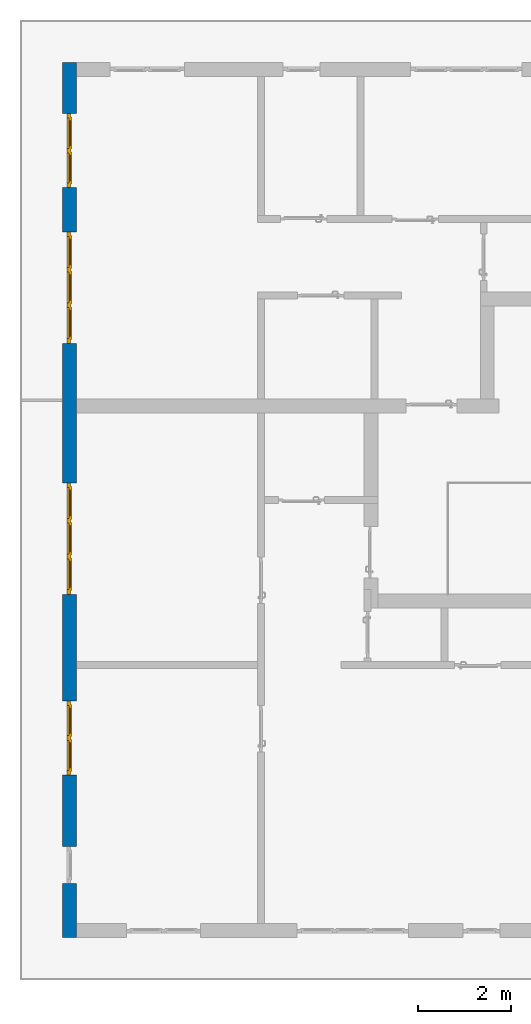
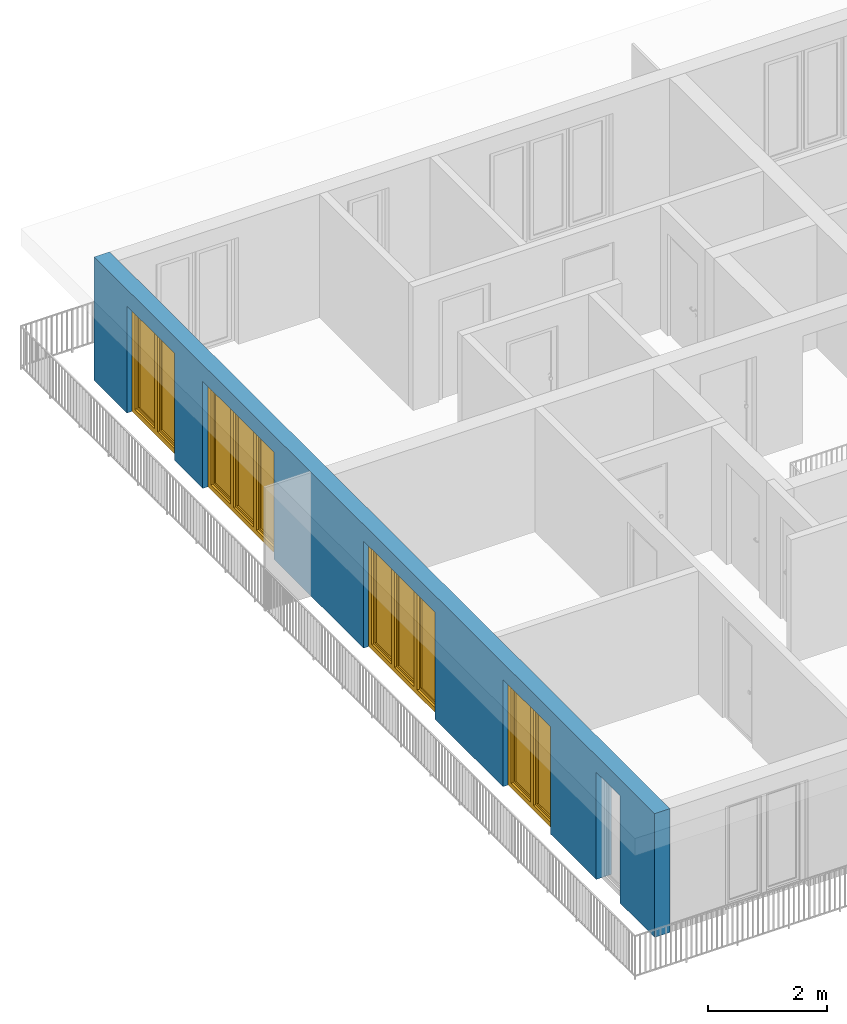
# One storey, part 11 of 54: 4 windows, 1 wall, 5 openings.
"""IFC4 building model written with IfcOpenShell, lengths in metres."""

import ifcopenshell
import ifcopenshell.guid

model = None  # the IFC model being written
_history = None  # IfcOwnerHistory: only IFC2X3 demands one
_inside = {}  # id of a spatial element -> (the spatial element, [elements in it])
_under = {}  # id of a project, library or spatial element -> (it, [spatial elements below it])
_declared = {}  # id of a project -> (the project, [libraries it declares])
_typed = {}  # id of a type object -> (the type object, [elements of that type])
_made_of = {}  # id of a material, layer set ... -> (it, [elements and type objects made of it])


def new_model(schema):
    """Start an empty IFC model of exactly this schema.

    Asked for "IFC4X3", IfcOpenShell would pick the latest addendum, in which some entities
    have other attributes; the version numbers below select the first issue.
    IFC2X3 requires an IfcOwnerHistory on every rooted entity: one is made here for all.
    """
    global model, _history
    if schema == "IFC4X3":
        model = ifcopenshell.file(schema_version=(4, 3, 0, 0))
    else:
        model = ifcopenshell.file(schema=schema)
    _inside.clear()
    _under.clear()
    _declared.clear()
    _typed.clear()
    _made_of.clear()
    _history = None
    if model.schema == "IFC2X3":
        org = make("IfcOrganization", Name="unknown")
        user = make(
            "IfcPersonAndOrganization",
            ThePerson=make("IfcPerson", FamilyName="unknown"),
            TheOrganization=org,
        )
        app = make(
            "IfcApplication",
            ApplicationDeveloper=org,
            Version="unknown",
            ApplicationFullName="unknown",
            ApplicationIdentifier="unknown",
        )
        _history = make(
            "IfcOwnerHistory",
            OwningUser=user,
            OwningApplication=app,
            ChangeAction="ADDED",
            CreationDate=0,
        )
    return model


def make(cls, **values):
    """One entity of the class cls with the attributes given. An attribute that is None is left unset."""
    return model.create_entity(
        cls, **{name: value for name, value in values.items() if value is not None}
    )


def entity(cls, *values):
    """Any entity or typed value of the class cls, its attributes in the order of the schema. None: left unset."""
    e = model.create_entity(cls)
    for i, value in enumerate(values):
        if value is not None:
            e[i] = value
    return e


def rooted(cls, **values):
    """An entity with a GlobalId (a new one), such as an element, a storey or a relation."""
    return make(cls, GlobalId=ifcopenshell.guid.new(), OwnerHistory=_history, **values)


def si_unit(unit_type, name, prefix=None):
    """IfcSIUnit, for example si_unit("LENGTHUNIT", "METRE", prefix="MILLI")."""
    return make("IfcSIUnit", UnitType=unit_type, Prefix=prefix, Name=name)


def converted_unit(unit_type, name, factor, base, dimensions=None, offset=None):
    """IfcConversionBasedUnit, such as the inch: factor (a typed value) times the base unit."""
    return make(
        "IfcConversionBasedUnit"
        if offset is None
        else "IfcConversionBasedUnitWithOffset",
        ConversionOffset=offset,
        Dimensions=None
        if dimensions is None
        else entity("IfcDimensionalExponents", *dimensions),
        UnitType=unit_type,
        Name=name,
        ConversionFactor=make(
            "IfcMeasureWithUnit", ValueComponent=factor, UnitComponent=base
        ),
    )


def derived_unit(unit_type, elements):
    """IfcDerivedUnit: a product of units, each with its exponent."""
    return make(
        "IfcDerivedUnit",
        Elements=[
            make("IfcDerivedUnitElement", Unit=unit, Exponent=power)
            for unit, power in elements
        ],
        UnitType=unit_type,
    )


def assignment(units):
    """IfcUnitAssignment: the units of a project."""
    return None if units is None else make("IfcUnitAssignment", Units=units)


def point(xyz):
    """IfcCartesianPoint."""
    return None if xyz is None else make("IfcCartesianPoint", Coordinates=xyz)


def direction(xyz):
    """IfcDirection."""
    return None if xyz is None else make("IfcDirection", DirectionRatios=xyz)


def frame(location, z_axis=None, x_axis=None):
    """IfcAxis2Placement3D, a coordinate frame: its origin and axes. An axis left out is left unset."""
    return make(
        "IfcAxis2Placement3D",
        Location=point(location),
        Axis=direction(z_axis),
        RefDirection=direction(x_axis),
    )


def origin_with_axes():
    """The frame at (0, 0, 0) with the z axis (0, 0, 1) and the x axis (1, 0, 0) written out."""
    return frame((0.0, 0.0, 0.0), z_axis=(0.0, 0.0, 1.0), x_axis=(1.0, 0.0, 0.0))


def place(relative_to, where):
    """IfcLocalPlacement: puts the frame where relative to a parent placement (None: the world)."""
    return make(
        "IfcLocalPlacement", PlacementRelTo=relative_to, RelativePlacement=where
    )


def context(
    kind, dimensions, precision=None, world=None, true_north=None, identifier=None
):
    """IfcGeometricRepresentationContext, for example the 3D "Model" context."""
    return make(
        "IfcGeometricRepresentationContext",
        ContextIdentifier=identifier,
        ContextType=kind,
        CoordinateSpaceDimension=dimensions,
        Precision=precision,
        WorldCoordinateSystem=world,
        TrueNorth=true_north,
    )


def subcontext(parent, identifier, kind, view, scale=None):
    """IfcGeometricRepresentationSubContext, for example "Body" below "Model"."""
    return make(
        "IfcGeometricRepresentationSubContext",
        ContextIdentifier=identifier,
        ContextType=kind,
        ParentContext=parent,
        TargetScale=scale,
        TargetView=view,
    )


def project(units=None, contexts=None):
    """IfcProject with its units and contexts."""
    return rooted(
        "IfcProject",
        Name="project",
        RepresentationContexts=contexts,
        UnitsInContext=assignment(units),
    )


def spatial(cls, under=None, at=None, **own):
    """A site, building, storey or space (cls), placed at a placement, below another one or the project."""
    s = rooted(cls, ObjectPlacement=at, **own)
    if under is not None:
        _under.setdefault(under.id(), (under, []))[1].append(s)
    return s


def point_list(points):
    """IfcCartesianPointList2D or 3D."""
    cls = (
        "IfcCartesianPointList2D" if len(points[0]) == 2 else "IfcCartesianPointList3D"
    )
    return make(cls, CoordList=points)


def polygons(points, faces, closed=None, point_numbers=None):
    """IfcPolygonalFaceSet: a face is its outer loop, then its inner loops; points numbered from 1."""
    made = []
    for loops in faces:
        if len(loops) == 1:
            made.append(make("IfcIndexedPolygonalFace", CoordIndex=loops[0]))
        else:
            made.append(
                make(
                    "IfcIndexedPolygonalFaceWithVoids",
                    CoordIndex=loops[0],
                    InnerCoordIndices=loops[1:],
                )
            )
    return make(
        "IfcPolygonalFaceSet",
        Coordinates=point_list(points),
        Closed=closed,
        Faces=made,
        PnIndex=point_numbers,
    )


def shape(context_of_items, identifier, shape_type, items):
    """IfcShapeRepresentation: the items that make up one representation, for example the "Body"."""
    return make(
        "IfcShapeRepresentation",
        ContextOfItems=context_of_items,
        RepresentationIdentifier=identifier,
        RepresentationType=shape_type,
        Items=items,
    )


def source(mapping_origin, context_of_items, identifier, shape_type, items):
    """IfcRepresentationMap: a shape defined once, which mapped items show again and again."""
    return make(
        "IfcRepresentationMap",
        MappingOrigin=mapping_origin,
        MappedRepresentation=shape(context_of_items, identifier, shape_type, items),
    )


def transform(
    local_origin,
    x_axis=None,
    y_axis=None,
    z_axis=None,
    scale=None,
    scale2=None,
    scale3=None,
    uniform=True,
):
    """IfcCartesianTransformationOperator3D, or its non-uniform kind. x_axis, y_axis, z_axis: its Axis1, 2, 3."""
    if uniform:
        return make(
            "IfcCartesianTransformationOperator3D",
            Axis1=direction(x_axis),
            Axis2=direction(y_axis),
            LocalOrigin=point(local_origin),
            Scale=scale,
            Axis3=direction(z_axis),
        )
    return make(
        "IfcCartesianTransformationOperator3DnonUniform",
        Axis1=direction(x_axis),
        Axis2=direction(y_axis),
        LocalOrigin=point(local_origin),
        Scale=scale,
        Axis3=direction(z_axis),
        Scale2=scale2,
        Scale3=scale3,
    )


def mapped(mapping_source, mapping_target):
    """IfcMappedItem: shows the shape of a source again, moved by a transform."""
    return make(
        "IfcMappedItem", MappingSource=mapping_source, MappingTarget=mapping_target
    )


def material(Name=None, Category=None):
    """IfcMaterial."""
    return make("IfcMaterial", Name=Name, Category=Category)


def made_of(thing, what):
    """Note that an element or type object is made of a material, layer set ...; save() writes the relation."""
    if what is not None:
        _made_of.setdefault(what.id(), (what, []))[1].append(thing)
    return thing


def type_object(cls, material=None, **own):
    """A type object (cls), such as IfcWallType, which elements share."""
    return made_of(rooted(cls, **own), material)


def element(
    cls,
    number,
    at=None,
    inside=None,
    cuts=None,
    type_object=None,
    material=None,
    context=None,
    identifier="Body",
    shape_type=None,
    held_by="IfcProductDefinitionShape",
    body=None,
    shapes=None,
    **own,
):
    """One element of the class cls, such as IfcWall. Its Tag is "e" and its number.

    at: its placement. inside: the storey or other place that contains it. cuts: it is an
    opening in that element (IfcRelVoidsElement). A single representation is given by context,
    identifier, shape_type and body (its items); several are given by shapes. held_by: the class
    of the entity that holds the representations. save() writes the other relations.
    """
    e = rooted(cls, Tag="e%d" % number, ObjectPlacement=at, **own)
    if body is not None:
        shapes = [shape(context, identifier, shape_type, body)]
    if shapes is not None:
        e.Representation = make(held_by, Representations=shapes)
    if inside is not None:
        _inside.setdefault(inside.id(), (inside, []))[1].append(e)
    if cuts is not None:
        rooted(
            "IfcRelVoidsElement", RelatingBuildingElement=cuts, RelatedOpeningElement=e
        )
    if type_object is not None:
        _typed.setdefault(type_object.id(), (type_object, []))[1].append(e)
    return made_of(e, material)


def fill(opening, filler):
    """IfcRelFillsElement: the door or window that sits in an opening."""
    return rooted(
        "IfcRelFillsElement",
        RelatingOpeningElement=opening,
        RelatedBuildingElement=filler,
    )


def aggregate(whole, parts):
    """IfcRelAggregates: a whole, such as a stair, and the parts it consists of."""
    return rooted("IfcRelAggregates", RelatingObject=whole, RelatedObjects=parts)


def save(model, path):
    """Write the relations noted so far, then the file.

    IfcRelAggregates (storeys below a building ...), IfcRelContainedInSpatialStructure (elements
    in a storey), IfcRelDefinesByType, IfcRelAssociatesMaterial and IfcRelDeclares: one each for
    every whole, place, type object, material and project.
    """
    for whole, parts in _under.values():
        aggregate(whole, parts)
    for where, things in _inside.values():
        rooted(
            "IfcRelContainedInSpatialStructure",
            RelatedElements=things,
            RelatingStructure=where,
        )
    for kind, things in _typed.values():
        rooted("IfcRelDefinesByType", RelatedObjects=things, RelatingType=kind)
    for what, things in _made_of.values():
        rooted("IfcRelAssociatesMaterial", RelatedObjects=things, RelatingMaterial=what)
    for by, libraries in _declared.values():
        rooted("IfcRelDeclares", RelatingContext=by, RelatedDefinitions=libraries)
    model.write(path)


model = new_model("IFC4")

# Units and contexts
model_context = context("Model", 3, precision=1e-05, world=origin_with_axes(), true_north=direction((0.0, 1.0)))
body_context = subcontext(model_context, "Body", "Model", "MODEL_VIEW")
ifc_project = project(units=[si_unit("LENGTHUNIT", "METRE"), si_unit("AREAUNIT", "SQUARE_METRE"), si_unit("VOLUMEUNIT", "CUBIC_METRE"), converted_unit("PLANEANGLEUNIT", "DEGREE", entity("IfcPlaneAngleMeasure", 0.0174532925199), si_unit("PLANEANGLEUNIT", "RADIAN"), dimensions=[0, 0, 0, 0, 0, 0, 0]), converted_unit("TIMEUNIT", "Year", entity("IfcTimeMeasure", 31556926.0), si_unit("TIMEUNIT", "SECOND"), dimensions=[0, 0, 1, 0, 0, 0, 0]), si_unit("MASSUNIT", "GRAM", prefix="KILO"), si_unit("THERMODYNAMICTEMPERATUREUNIT", "DEGREE_CELSIUS"), si_unit("LUMINOUSINTENSITYUNIT", "LUMEN"), si_unit("ENERGYUNIT", "JOULE", prefix="MEGA"), derived_unit("THERMALCONDUCTANCEUNIT", [(si_unit("POWERUNIT", "WATT"), 1), (si_unit("LENGTHUNIT", "METRE"), -1), (si_unit("THERMODYNAMICTEMPERATUREUNIT", "KELVIN"), -1)]), derived_unit("SPECIFICHEATCAPACITYUNIT", [(si_unit("ENERGYUNIT", "JOULE"), 1), (si_unit("MASSUNIT", "GRAM", prefix="KILO"), -1), (si_unit("THERMODYNAMICTEMPERATUREUNIT", "KELVIN"), -1)]), derived_unit("MASSDENSITYUNIT", [(si_unit("MASSUNIT", "GRAM", prefix="KILO"), 1), (si_unit("VOLUMEUNIT", "CUBIC_METRE"), -1)])], contexts=[model_context])

# Site, building, storey
site_placement = place(None, origin_with_axes())
site = spatial("IfcSite", under=ifc_project, at=site_placement, CompositionType="ELEMENT")
building_placement = place(site_placement, origin_with_axes())
building = spatial("IfcBuilding", under=site, at=building_placement, CompositionType="ELEMENT")
storey_placement = place(building_placement, frame((0.0, 0.0, 9.18), z_axis=(0.0, 0.0, 1.0), x_axis=(1.0, 0.0, 0.0)))
storey = spatial("IfcBuildingStorey", under=building, at=storey_placement, Name="3. Geschoss", CompositionType="ELEMENT", Elevation=9.18)

# Wall, openings, windows
ifc_material = material()
wall_type = type_object("IfcWallType", Name="300", PredefinedType="NOTDEFINED")
wall_placement = place(storey_placement, frame((-11.7421993804, -9.92881223104, 0.0), z_axis=(0.0, 0.0, 1.0), x_axis=(0.0, 1.0, 0.0)))
wall = element("IfcWall", 1, at=wall_placement, inside=storey, type_object=wall_type, material=ifc_material, Name="Wand-001", PredefinedType="NOTDEFINED", context=body_context, shape_type="Tessellation", body=[
    polygons([(1.16441876325, -0.3, 0.0), (1.16441876325, -0.3, 2.2), (1.96441876325, -0.3, 2.2), (1.96441876325, -0.3, 0.0), (3.5, -0.3, 0.0), (3.5, -0.3, 2.2), (5.1, -0.3, 2.2), (5.1, -0.3, 0.0), (7.3921181063, -0.3, 0.0), (7.3921181063, -0.3, 2.2), (9.7921181063, -0.3, 2.2), (9.7921181063, -0.3, 0.0), (12.8, -0.3, 0.0), (12.8, -0.3, 2.2), (15.2, -0.3, 2.2), (15.2, -0.3, 0.0), (16.15, -0.3, 0.0), (16.15, -0.3, 2.2), (17.75, -0.3, 2.2), (17.75, -0.3, 0.0), (18.85, -0.3, 0.0), (18.85, -0.3, 2.54), (0.0, -0.3, 2.54), (0.0, -0.3, 0.0), (1.16441876325, -0.1, 0.0), (1.16441876325, -0.1, 2.2), (1.96441876325, -0.1, 2.2), (1.96441876325, -0.1, 0.0), (1.96441876325, 0.0, 0.0), (3.5, 0.0, 0.0), (3.5, -0.1, 0.0), (3.5, -0.1, 2.2), (5.1, -0.1, 2.2), (5.1, -0.1, 0.0), (5.1, 0.0, 0.0), (7.3921181063, 0.0, 0.0), (7.3921181063, -0.1, 0.0), (7.3921181063, -0.1, 2.2), (9.7921181063, -0.1, 2.2), (9.7921181063, -0.1, 0.0), (9.7921181063, 0.0, 0.0), (12.8, 0.0, 0.0), (12.8, -0.1, 0.0), (12.8, -0.1, 2.2), (15.2, -0.1, 2.2), (15.2, -0.1, 0.0), (15.2, 0.0, 0.0), (16.15, 0.0, 0.0), (16.15, -0.1, 0.0), (16.15, -0.1, 2.2), (17.75, -0.1, 2.2), (17.75, -0.1, 0.0), (17.75, 0.0, 0.0), (18.85, 0.0, 0.0), (18.85, 0.0, 2.54), (0.0, 0.0, 2.54), (0.0, 0.0, 0.0), (1.16441876325, 0.0, 0.0), (1.16441876325, 0.0, 2.2), (1.96441876325, 0.0, 2.2), (17.75, 0.0, 2.2), (16.15, 0.0, 2.2), (15.2, 0.0, 2.2), (12.8, 0.0, 2.2), (9.7921181063, 0.0, 2.2), (7.3921181063, 0.0, 2.2), (5.1, 0.0, 2.2), (3.5, 0.0, 2.2)], [[[1, 2, 3, 4, 5, 6, 7, 8, 9, 10, 11, 12, 13, 14, 15, 16, 17, 18, 19, 20, 21, 22, 23, 24]], [[2, 1, 25, 26]], [[3, 2, 26, 27]], [[4, 3, 27, 28]], [[4, 28, 29, 30, 31, 5]], [[31, 32, 6, 5]], [[32, 33, 7, 6]], [[33, 34, 8, 7]], [[8, 34, 35, 36, 37, 9]], [[10, 9, 37, 38]], [[11, 10, 38, 39]], [[12, 11, 39, 40]], [[12, 40, 41, 42, 43, 13]], [[43, 44, 14, 13]], [[44, 45, 15, 14]], [[45, 46, 16, 15]], [[16, 46, 47, 48, 49, 17]], [[18, 17, 49, 50]], [[19, 18, 50, 51]], [[20, 19, 51, 52]], [[52, 53, 54, 21, 20]], [[22, 21, 54, 55]], [[22, 55, 56, 23]], [[56, 57, 24, 23]], [[25, 1, 24, 57, 58]], [[26, 25, 58, 59]], [[27, 26, 59, 60]], [[28, 27, 60, 29]], [[30, 29, 60, 59, 58, 57, 56, 55, 54, 53, 61, 62, 48, 47, 63, 64, 42, 41, 65, 66, 36, 35, 67, 68]], [[30, 68, 32, 31]], [[68, 67, 33, 32]], [[67, 35, 34, 33]], [[38, 37, 36, 66]], [[39, 38, 66, 65]], [[40, 39, 65, 41]], [[42, 64, 44, 43]], [[64, 63, 45, 44]], [[63, 47, 46, 45]], [[50, 49, 48, 62]], [[51, 50, 62, 61]], [[52, 51, 61, 53]]], closed=True),
])
opening_1_placement = place(wall_placement, frame((16.95, 0.0, 0.0), z_axis=(0.0, 0.0, 1.0), x_axis=(1.0, 0.0, 0.0)))
opening_1 = element("IfcOpeningElement", 2, at=opening_1_placement, cuts=wall, Name="Fenster-001", context=body_context, identifier="Reference", shape_type="Tessellation", body=[
    polygons([(-0.8, -0.1, 0.0), (-0.8, -0.1, 2.2), (-0.8, 0.000999999999999, 2.2), (-0.8, 0.000999999999999, 0.0), (-0.8, -0.301, 0.0), (-0.8, -0.301, 2.2), (0.8, -0.1, 2.2), (0.8, 0.000999999999999, 2.2), (0.8, -0.301, 2.2), (0.8, 0.000999999999999, 0.0), (0.8, -0.1, 0.0), (0.8, -0.301, 0.0)], [[[1, 2, 3, 4]], [[2, 1, 5, 6]], [[7, 8, 3, 2, 6, 9]], [[8, 10, 4, 3]], [[1, 4, 10, 11, 12, 5]], [[6, 5, 12, 9]], [[7, 11, 10, 8]], [[11, 7, 9, 12]]], closed=True),
])
opening_2_placement = place(wall_placement, frame((14.0, 0.0, 0.0), z_axis=(0.0, 0.0, 1.0), x_axis=(1.0, 0.0, 0.0)))
opening_2 = element("IfcOpeningElement", 3, at=opening_2_placement, cuts=wall, Name="Fenster-002", context=body_context, identifier="Reference", shape_type="Tessellation", body=[
    polygons([(-1.2, -0.1, 0.0), (-1.2, -0.1, 2.2), (-1.2, 0.000999999999999, 2.2), (-1.2, 0.000999999999999, 0.0), (-1.2, -0.301, 0.0), (-1.2, -0.301, 2.2), (1.2, -0.1, 2.2), (1.2, 0.000999999999999, 2.2), (1.2, -0.301, 2.2), (1.2, 0.000999999999999, 0.0), (1.2, -0.1, 0.0), (1.2, -0.301, 0.0)], [[[1, 2, 3, 4]], [[2, 1, 5, 6]], [[7, 8, 3, 2, 6, 9]], [[8, 10, 4, 3]], [[1, 4, 10, 11, 12, 5]], [[6, 5, 12, 9]], [[7, 11, 10, 8]], [[11, 7, 9, 12]]], closed=True),
])
opening_3_placement = place(wall_placement, frame((8.5921181063, 0.0, 0.0), z_axis=(0.0, 0.0, 1.0), x_axis=(1.0, 0.0, 0.0)))
opening_3 = element("IfcOpeningElement", 4, at=opening_3_placement, cuts=wall, Name="Fenster-002", context=body_context, identifier="Reference", shape_type="Tessellation", body=[
    polygons([(-1.2, -0.1, 0.0), (-1.2, -0.1, 2.2), (-1.2, 0.000999999999999, 2.2), (-1.2, 0.000999999999999, 0.0), (-1.2, -0.301, 0.0), (-1.2, -0.301, 2.2), (1.2, -0.1, 2.2), (1.2, 0.000999999999999, 2.2), (1.2, -0.301, 2.2), (1.2, 0.000999999999999, 0.0), (1.2, -0.1, 0.0), (1.2, -0.301, 0.0)], [[[1, 2, 3, 4]], [[2, 1, 5, 6]], [[7, 8, 3, 2, 6, 9]], [[8, 10, 4, 3]], [[1, 4, 10, 11, 12, 5]], [[6, 5, 12, 9]], [[7, 11, 10, 8]], [[11, 7, 9, 12]]], closed=True),
])
opening_4_placement = place(wall_placement, frame((4.3, 0.0, 0.0), z_axis=(0.0, 0.0, 1.0), x_axis=(1.0, 0.0, 0.0)))
opening_4 = element("IfcOpeningElement", 5, at=opening_4_placement, cuts=wall, Name="Fenster-001", context=body_context, identifier="Reference", shape_type="Tessellation", body=[
    polygons([(-0.8, -0.1, 0.0), (-0.8, -0.1, 2.2), (-0.8, 0.000999999999999, 2.2), (-0.8, 0.000999999999999, 0.0), (-0.8, -0.301, 0.0), (-0.8, -0.301, 2.2), (0.8, -0.1, 2.2), (0.8, 0.000999999999999, 2.2), (0.8, -0.301, 2.2), (0.8, 0.000999999999999, 0.0), (0.8, -0.1, 0.0), (0.8, -0.301, 0.0)], [[[1, 2, 3, 4]], [[2, 1, 5, 6]], [[7, 8, 3, 2, 6, 9]], [[8, 10, 4, 3]], [[1, 4, 10, 11, 12, 5]], [[6, 5, 12, 9]], [[7, 11, 10, 8]], [[11, 7, 9, 12]]], closed=True),
])
opening_5_placement = place(wall_placement, frame((1.56441876325, 0.0, 0.0), z_axis=(0.0, 0.0, 1.0), x_axis=(1.0, 0.0, 0.0)))
element("IfcOpeningElement", 6, at=opening_5_placement, cuts=wall, Name="Fenster-003", context=body_context, identifier="Reference", shape_type="Tessellation", body=[
    polygons([(-0.4, -0.1, 0.0), (-0.4, -0.1, 2.2), (-0.4, 0.000999999999999, 2.2), (-0.4, 0.000999999999999, 0.0), (-0.4, -0.301, 0.0), (-0.4, -0.301, 2.2), (0.4, -0.1, 2.2), (0.4, 0.000999999999999, 2.2), (0.4, -0.301, 2.2), (0.4, 0.000999999999999, 0.0), (0.4, -0.1, 0.0), (0.4, -0.301, 0.0)], [[[1, 2, 3, 4]], [[2, 1, 5, 6]], [[7, 8, 3, 2, 6, 9]], [[8, 10, 4, 3]], [[1, 4, 10, 11, 12, 5]], [[6, 5, 12, 9]], [[7, 11, 10, 8]], [[11, 7, 9, 12]]], closed=True),
])
window_type_1 = type_object("IfcWindowType", Name="2-1+1 26", PartitioningType="DOUBLE_PANEL_VERTICAL", PredefinedType="WINDOW")
shared_shape_1 = source(origin_with_axes(), body_context, "Body", "Tessellation", [
    polygons([(0.8, -0.07, 0.0), (0.7, -0.07, 0.1), (0.7, 0.0, 0.1), (0.8, 0.0, 0.0), (0.8, -0.07, 2.2), (0.7, -0.07, 2.1), (0.7, 0.0, 2.1), (0.8, 0.0, 2.2)], [[[1, 2, 3, 4]], [[1, 5, 6, 2]], [[2, 6, 7, 3]], [[4, 3, 7, 8]], [[5, 1, 4, 8]], [[6, 5, 8, 7]]], closed=True),
    polygons([(-0.8, -0.07, 0.0), (-0.8, -0.07, 2.2), (-0.8, 0.0, 2.2), (-0.8, 0.0, 0.0), (-0.7, -0.07, 0.1), (-0.7, -0.07, 2.1), (-0.7, 0.0, 2.1), (-0.7, 0.0, 0.1)], [[[1, 2, 3, 4]], [[1, 5, 6, 2]], [[2, 6, 7, 3]], [[4, 3, 7, 8]], [[5, 1, 4, 8]], [[6, 5, 8, 7]]], closed=True),
    polygons([(0.8, -0.07, 0.0), (-0.8, -0.07, 0.0), (-0.8, 0.0, 0.0), (0.8, 0.0, 0.0), (0.7, -0.07, 0.1), (0.05, -0.07, 0.1), (-0.05, -0.07, 0.1), (-0.7, -0.07, 0.1), (-0.7, 0.0, 0.1), (-0.05, 0.0, 0.1), (0.05, 0.0, 0.1), (0.7, 0.0, 0.1)], [[[1, 2, 3, 4]], [[1, 5, 6, 7, 8, 2]], [[2, 8, 9, 3]], [[4, 3, 9, 10, 11, 12]], [[5, 1, 4, 12]], [[6, 5, 12, 11]], [[7, 6, 11, 10]], [[8, 7, 10, 9]]], closed=True),
    polygons([(0.8, -0.07, 2.2), (0.7, -0.07, 2.1), (0.7, 0.0, 2.1), (0.8, 0.0, 2.2), (-0.8, -0.07, 2.2), (-0.7, -0.07, 2.1), (-0.05, -0.07, 2.1), (0.05, -0.07, 2.1), (0.05, 0.0, 2.1), (-0.05, 0.0, 2.1), (-0.7, 0.0, 2.1), (-0.8, 0.0, 2.2)], [[[1, 2, 3, 4]], [[1, 5, 6, 7, 8, 2]], [[2, 8, 9, 3]], [[4, 3, 9, 10, 11, 12]], [[5, 1, 4, 12]], [[6, 5, 12, 11]], [[7, 6, 11, 10]], [[8, 7, 10, 9]]], closed=True),
    polygons([(0.05, -0.07, 0.1), (-0.05, -0.07, 0.1), (-0.05, 0.0, 0.1), (0.05, 0.0, 0.1), (0.05, -0.07, 2.1), (-0.05, -0.07, 2.1), (-0.05, 0.0, 2.1), (0.05, 0.0, 2.1)], [[[1, 2, 3, 4]], [[1, 5, 6, 2]], [[2, 6, 7, 3]], [[4, 3, 7, 8]], [[5, 1, 4, 8]], [[6, 5, 8, 7]]], closed=True),
    polygons([(0.72, 0.0, 0.08), (0.65, 0.0, 0.15), (0.65, 0.03, 0.15), (0.72, 0.03, 0.08), (0.72, 0.0, 2.12), (0.65, 0.0, 2.05), (0.65, 0.03, 2.05), (0.72, 0.03, 2.12)], [[[1, 2, 3, 4]], [[1, 5, 6, 2]], [[2, 6, 7, 3]], [[4, 3, 7, 8]], [[5, 1, 4, 8]], [[6, 5, 8, 7]]], closed=True),
    polygons([(0.03, 0.0, 0.08), (0.03, 0.03, 0.08), (0.1, 0.03, 0.15), (0.1, 0.0, 0.15), (0.03, 0.0, 2.12), (0.03, 0.03, 2.12), (0.1, 0.03, 2.05), (0.1, 0.0, 2.05)], [[[1, 2, 3, 4]], [[5, 6, 2, 1]], [[2, 6, 7, 3]], [[4, 3, 7, 8]], [[1, 4, 8, 5]], [[8, 7, 6, 5]]], closed=True),
    polygons([(0.72, 0.0, 0.08), (0.03, 0.0, 0.08), (0.03, 0.03, 0.08), (0.72, 0.03, 0.08), (0.65, 0.0, 0.15), (0.1, 0.0, 0.15), (0.1, 0.03, 0.15), (0.65, 0.03, 0.15)], [[[1, 2, 3, 4]], [[1, 5, 6, 2]], [[2, 6, 7, 3]], [[4, 3, 7, 8]], [[5, 1, 4, 8]], [[6, 5, 8, 7]]], closed=True),
    polygons([(0.72, 0.0, 2.12), (0.72, 0.03, 2.12), (0.03, 0.03, 2.12), (0.03, 0.0, 2.12), (0.65, 0.0, 2.05), (0.65, 0.03, 2.05), (0.1, 0.03, 2.05), (0.1, 0.0, 2.05)], [[[1, 2, 3, 4]], [[5, 6, 2, 1]], [[2, 6, 7, 3]], [[4, 3, 7, 8]], [[1, 4, 8, 5]], [[8, 7, 6, 5]]], closed=True),
    polygons([(0.7, -0.03, 0.1), (0.65, -0.03, 0.15), (0.65, 0.0, 0.15), (0.7, 0.0, 0.1), (0.7, -0.03, 2.1), (0.65, -0.03, 2.05), (0.65, 0.0, 2.05), (0.7, 0.0, 2.1)], [[[1, 2, 3, 4]], [[1, 5, 6, 2]], [[2, 6, 7, 3]], [[4, 3, 7, 8]], [[5, 1, 4, 8]], [[6, 5, 8, 7]]], closed=True),
    polygons([(0.05, -0.03, 0.1), (0.05, 0.0, 0.1), (0.1, 0.0, 0.15), (0.1, -0.03, 0.15), (0.05, -0.03, 2.1), (0.05, 0.0, 2.1), (0.1, 0.0, 2.05), (0.1, -0.03, 2.05)], [[[1, 2, 3, 4]], [[5, 6, 2, 1]], [[2, 6, 7, 3]], [[4, 3, 7, 8]], [[1, 4, 8, 5]], [[8, 7, 6, 5]]], closed=True),
    polygons([(0.7, -0.03, 0.1), (0.05, -0.03, 0.1), (0.05, 0.0, 0.1), (0.7, 0.0, 0.1), (0.65, -0.03, 0.15), (0.1, -0.03, 0.15), (0.1, 0.0, 0.15), (0.65, 0.0, 0.15)], [[[1, 2, 3, 4]], [[1, 5, 6, 2]], [[2, 6, 7, 3]], [[4, 3, 7, 8]], [[5, 1, 4, 8]], [[6, 5, 8, 7]]], closed=True),
    polygons([(0.7, -0.03, 2.1), (0.7, 0.0, 2.1), (0.05, 0.0, 2.1), (0.05, -0.03, 2.1), (0.65, -0.03, 2.05), (0.65, 0.0, 2.05), (0.1, 0.0, 2.05), (0.1, -0.03, 2.05)], [[[1, 2, 3, 4]], [[5, 6, 2, 1]], [[2, 6, 7, 3]], [[4, 3, 7, 8]], [[1, 4, 8, 5]], [[8, 7, 6, 5]]], closed=True),
    polygons([(0.65, -0.005, 0.15), (0.1, -0.005, 0.15), (0.1, 0.005, 0.15), (0.65, 0.005, 0.15), (0.65, -0.005, 2.05), (0.1, -0.005, 2.05), (0.1, 0.005, 2.05), (0.65, 0.005, 2.05)], [[[1, 2, 3, 4]], [[1, 5, 6, 2]], [[2, 6, 7, 3]], [[4, 3, 7, 8]], [[5, 1, 4, 8]], [[6, 5, 8, 7]]], closed=True),
    polygons([(-0.03, 0.0, 0.08), (-0.1, 0.0, 0.15), (-0.1, 0.03, 0.15), (-0.03, 0.03, 0.08), (-0.03, 0.0, 2.12), (-0.1, 0.0, 2.05), (-0.1, 0.03, 2.05), (-0.03, 0.03, 2.12)], [[[1, 2, 3, 4]], [[1, 5, 6, 2]], [[2, 6, 7, 3]], [[4, 3, 7, 8]], [[5, 1, 4, 8]], [[6, 5, 8, 7]]], closed=True),
    polygons([(-0.72, 0.0, 0.08), (-0.72, 0.03, 0.08), (-0.65, 0.03, 0.15), (-0.65, 0.0, 0.15), (-0.72, 0.0, 2.12), (-0.72, 0.03, 2.12), (-0.65, 0.03, 2.05), (-0.65, 0.0, 2.05)], [[[1, 2, 3, 4]], [[5, 6, 2, 1]], [[2, 6, 7, 3]], [[4, 3, 7, 8]], [[1, 4, 8, 5]], [[8, 7, 6, 5]]], closed=True),
    polygons([(-0.03, 0.0, 0.08), (-0.72, 0.0, 0.08), (-0.72, 0.03, 0.08), (-0.03, 0.03, 0.08), (-0.1, 0.0, 0.15), (-0.65, 0.0, 0.15), (-0.65, 0.03, 0.15), (-0.1, 0.03, 0.15)], [[[1, 2, 3, 4]], [[1, 5, 6, 2]], [[2, 6, 7, 3]], [[4, 3, 7, 8]], [[5, 1, 4, 8]], [[6, 5, 8, 7]]], closed=True),
    polygons([(-0.03, 0.0, 2.12), (-0.03, 0.03, 2.12), (-0.72, 0.03, 2.12), (-0.72, 0.0, 2.12), (-0.1, 0.0, 2.05), (-0.1, 0.03, 2.05), (-0.65, 0.03, 2.05), (-0.65, 0.0, 2.05)], [[[1, 2, 3, 4]], [[5, 6, 2, 1]], [[2, 6, 7, 3]], [[4, 3, 7, 8]], [[1, 4, 8, 5]], [[8, 7, 6, 5]]], closed=True),
    polygons([(-0.05, -0.03, 0.1), (-0.1, -0.03, 0.15), (-0.1, 0.0, 0.15), (-0.05, 0.0, 0.1), (-0.05, -0.03, 2.1), (-0.1, -0.03, 2.05), (-0.1, 0.0, 2.05), (-0.05, 0.0, 2.1)], [[[1, 2, 3, 4]], [[1, 5, 6, 2]], [[2, 6, 7, 3]], [[4, 3, 7, 8]], [[5, 1, 4, 8]], [[6, 5, 8, 7]]], closed=True),
    polygons([(-0.7, -0.03, 0.1), (-0.7, 0.0, 0.1), (-0.65, 0.0, 0.15), (-0.65, -0.03, 0.15), (-0.7, -0.03, 2.1), (-0.7, 0.0, 2.1), (-0.65, 0.0, 2.05), (-0.65, -0.03, 2.05)], [[[1, 2, 3, 4]], [[5, 6, 2, 1]], [[2, 6, 7, 3]], [[4, 3, 7, 8]], [[1, 4, 8, 5]], [[8, 7, 6, 5]]], closed=True),
    polygons([(-0.05, -0.03, 0.1), (-0.7, -0.03, 0.1), (-0.7, 0.0, 0.1), (-0.05, 0.0, 0.1), (-0.1, -0.03, 0.15), (-0.65, -0.03, 0.15), (-0.65, 0.0, 0.15), (-0.1, 0.0, 0.15)], [[[1, 2, 3, 4]], [[1, 5, 6, 2]], [[2, 6, 7, 3]], [[4, 3, 7, 8]], [[5, 1, 4, 8]], [[6, 5, 8, 7]]], closed=True),
    polygons([(-0.05, -0.03, 2.1), (-0.05, 0.0, 2.1), (-0.7, 0.0, 2.1), (-0.7, -0.03, 2.1), (-0.1, -0.03, 2.05), (-0.1, 0.0, 2.05), (-0.65, 0.0, 2.05), (-0.65, -0.03, 2.05)], [[[1, 2, 3, 4]], [[5, 6, 2, 1]], [[2, 6, 7, 3]], [[4, 3, 7, 8]], [[1, 4, 8, 5]], [[8, 7, 6, 5]]], closed=True),
    polygons([(-0.1, -0.005, 0.15), (-0.65, -0.005, 0.15), (-0.65, 0.005, 0.15), (-0.1, 0.005, 0.15), (-0.1, -0.005, 2.05), (-0.65, -0.005, 2.05), (-0.65, 0.005, 2.05), (-0.1, 0.005, 2.05)], [[[1, 2, 3, 4]], [[1, 5, 6, 2]], [[2, 6, 7, 3]], [[4, 3, 7, 8]], [[5, 1, 4, 8]], [[6, 5, 8, 7]]], closed=True),
])
window_1_placement = place(opening_1_placement, frame((0.8, 0.0, 0.0), z_axis=(0.0, 0.0, 1.0), x_axis=(-1.0, 0.0, 0.0)))
window_1 = element("IfcWindow", 7, at=window_1_placement, inside=storey, type_object=window_type_1, Name="Fenster-001", OverallHeight=2.2, OverallWidth=1.6, PredefinedType="WINDOW", context=body_context, shape_type="MappedRepresentation", body=[
    mapped(shared_shape_1, transform((0.8, 0.17, 0.0))),
])
fill(opening_1, window_1)
window_2_placement = place(opening_4_placement, frame((0.8, 0.0, 0.0), z_axis=(0.0, 0.0, 1.0), x_axis=(-1.0, 0.0, 0.0)))
window_2 = element("IfcWindow", 8, at=window_2_placement, inside=storey, type_object=window_type_1, Name="Fenster-001", OverallHeight=2.2, OverallWidth=1.6, PredefinedType="WINDOW", context=body_context, shape_type="MappedRepresentation", body=[
    mapped(shared_shape_1, transform((0.8, 0.17, 0.0))),
])
fill(opening_4, window_2)
window_type_2 = type_object("IfcWindowType", Name="3-1+1+1 26", PartitioningType="TRIPLE_PANEL_VERTICAL", PredefinedType="WINDOW")
shared_shape_2 = source(origin_with_axes(), body_context, "Body", "Tessellation", [
    polygons([(1.2, -0.07, 0.0), (1.1, -0.07, 0.1), (1.1, 0.0, 0.1), (1.2, 0.0, 0.0), (1.2, -0.07, 2.2), (1.1, -0.07, 2.1), (1.1, 0.0, 2.1), (1.2, 0.0, 2.2)], [[[1, 2, 3, 4]], [[1, 5, 6, 2]], [[2, 6, 7, 3]], [[4, 3, 7, 8]], [[5, 1, 4, 8]], [[6, 5, 8, 7]]], closed=True),
    polygons([(-1.2, -0.07, 0.0), (-1.2, -0.07, 2.2), (-1.2, 0.0, 2.2), (-1.2, 0.0, 0.0), (-1.1, -0.07, 0.1), (-1.1, -0.07, 2.1), (-1.1, 0.0, 2.1), (-1.1, 0.0, 0.1)], [[[1, 2, 3, 4]], [[1, 5, 6, 2]], [[2, 6, 7, 3]], [[4, 3, 7, 8]], [[5, 1, 4, 8]], [[6, 5, 8, 7]]], closed=True),
    polygons([(1.2, -0.07, 0.0), (-1.2, -0.07, 0.0), (-1.2, 0.0, 0.0), (1.2, 0.0, 0.0), (1.1, -0.07, 0.1), (0.433333333333, -0.07, 0.1), (0.333333333333, -0.07, 0.1), (-0.333333333333, -0.07, 0.1), (-0.433333333333, -0.07, 0.1), (-1.1, -0.07, 0.1), (-1.1, 0.0, 0.1), (-0.433333333333, 0.0, 0.1), (-0.333333333333, 0.0, 0.1), (0.333333333333, 0.0, 0.1), (0.433333333333, 0.0, 0.1), (1.1, 0.0, 0.1)], [[[1, 2, 3, 4]], [[1, 5, 6, 7, 8, 9, 10, 2]], [[2, 10, 11, 3]], [[4, 3, 11, 12, 13, 14, 15, 16]], [[5, 1, 4, 16]], [[6, 5, 16, 15]], [[7, 6, 15, 14]], [[8, 7, 14, 13]], [[9, 8, 13, 12]], [[10, 9, 12, 11]]], closed=True),
    polygons([(1.2, -0.07, 2.2), (1.1, -0.07, 2.1), (1.1, 0.0, 2.1), (1.2, 0.0, 2.2), (-1.2, -0.07, 2.2), (-1.1, -0.07, 2.1), (-0.433333333333, -0.07, 2.1), (-0.333333333333, -0.07, 2.1), (0.333333333333, -0.07, 2.1), (0.433333333333, -0.07, 2.1), (0.433333333333, 0.0, 2.1), (0.333333333333, 0.0, 2.1), (-0.333333333333, 0.0, 2.1), (-0.433333333333, 0.0, 2.1), (-1.1, 0.0, 2.1), (-1.2, 0.0, 2.2)], [[[1, 2, 3, 4]], [[1, 5, 6, 7, 8, 9, 10, 2]], [[2, 10, 11, 3]], [[4, 3, 11, 12, 13, 14, 15, 16]], [[5, 1, 4, 16]], [[6, 5, 16, 15]], [[7, 6, 15, 14]], [[8, 7, 14, 13]], [[9, 8, 13, 12]], [[10, 9, 12, 11]]], closed=True),
    polygons([(-0.333333333333, -0.07, 0.1), (-0.433333333333, -0.07, 0.1), (-0.433333333333, 0.0, 0.1), (-0.333333333333, 0.0, 0.1), (-0.333333333333, -0.07, 2.1), (-0.433333333333, -0.07, 2.1), (-0.433333333333, 0.0, 2.1), (-0.333333333333, 0.0, 2.1)], [[[1, 2, 3, 4]], [[1, 5, 6, 2]], [[2, 6, 7, 3]], [[4, 3, 7, 8]], [[5, 1, 4, 8]], [[6, 5, 8, 7]]], closed=True),
    polygons([(0.433333333333, -0.07, 0.1), (0.333333333333, -0.07, 0.1), (0.333333333333, 0.0, 0.1), (0.433333333333, 0.0, 0.1), (0.433333333333, -0.07, 2.1), (0.333333333333, -0.07, 2.1), (0.333333333333, 0.0, 2.1), (0.433333333333, 0.0, 2.1)], [[[1, 2, 3, 4]], [[1, 5, 6, 2]], [[2, 6, 7, 3]], [[4, 3, 7, 8]], [[5, 1, 4, 8]], [[6, 5, 8, 7]]], closed=True),
    polygons([(1.12, 0.0, 0.08), (1.05, 0.0, 0.15), (1.05, 0.03, 0.15), (1.12, 0.03, 0.08), (1.12, 0.0, 2.12), (1.05, 0.0, 2.05), (1.05, 0.03, 2.05), (1.12, 0.03, 2.12)], [[[1, 2, 3, 4]], [[1, 5, 6, 2]], [[2, 6, 7, 3]], [[4, 3, 7, 8]], [[5, 1, 4, 8]], [[6, 5, 8, 7]]], closed=True),
    polygons([(0.413333333333, 0.0, 0.08), (0.413333333333, 0.03, 0.08), (0.483333333333, 0.03, 0.15), (0.483333333333, 0.0, 0.15), (0.413333333333, 0.0, 2.12), (0.413333333333, 0.03, 2.12), (0.483333333333, 0.03, 2.05), (0.483333333333, 0.0, 2.05)], [[[1, 2, 3, 4]], [[5, 6, 2, 1]], [[2, 6, 7, 3]], [[4, 3, 7, 8]], [[1, 4, 8, 5]], [[8, 7, 6, 5]]], closed=True),
    polygons([(1.12, 0.0, 0.08), (0.413333333333, 0.0, 0.08), (0.413333333333, 0.03, 0.08), (1.12, 0.03, 0.08), (1.05, 0.0, 0.15), (0.483333333333, 0.0, 0.15), (0.483333333333, 0.03, 0.15), (1.05, 0.03, 0.15)], [[[1, 2, 3, 4]], [[1, 5, 6, 2]], [[2, 6, 7, 3]], [[4, 3, 7, 8]], [[5, 1, 4, 8]], [[6, 5, 8, 7]]], closed=True),
    polygons([(1.12, 0.0, 2.12), (1.12, 0.03, 2.12), (0.413333333333, 0.03, 2.12), (0.413333333333, 0.0, 2.12), (1.05, 0.0, 2.05), (1.05, 0.03, 2.05), (0.483333333333, 0.03, 2.05), (0.483333333333, 0.0, 2.05)], [[[1, 2, 3, 4]], [[5, 6, 2, 1]], [[2, 6, 7, 3]], [[4, 3, 7, 8]], [[1, 4, 8, 5]], [[8, 7, 6, 5]]], closed=True),
    polygons([(1.1, -0.03, 0.1), (1.05, -0.03, 0.15), (1.05, 0.0, 0.15), (1.1, 0.0, 0.1), (1.1, -0.03, 2.1), (1.05, -0.03, 2.05), (1.05, 0.0, 2.05), (1.1, 0.0, 2.1)], [[[1, 2, 3, 4]], [[1, 5, 6, 2]], [[2, 6, 7, 3]], [[4, 3, 7, 8]], [[5, 1, 4, 8]], [[6, 5, 8, 7]]], closed=True),
    polygons([(0.433333333333, -0.03, 0.1), (0.433333333333, 0.0, 0.1), (0.483333333333, 0.0, 0.15), (0.483333333333, -0.03, 0.15), (0.433333333333, -0.03, 2.1), (0.433333333333, 0.0, 2.1), (0.483333333333, 0.0, 2.05), (0.483333333333, -0.03, 2.05)], [[[1, 2, 3, 4]], [[5, 6, 2, 1]], [[2, 6, 7, 3]], [[4, 3, 7, 8]], [[1, 4, 8, 5]], [[8, 7, 6, 5]]], closed=True),
    polygons([(1.1, -0.03, 0.1), (0.433333333333, -0.03, 0.1), (0.433333333333, 0.0, 0.1), (1.1, 0.0, 0.1), (1.05, -0.03, 0.15), (0.483333333333, -0.03, 0.15), (0.483333333333, 0.0, 0.15), (1.05, 0.0, 0.15)], [[[1, 2, 3, 4]], [[1, 5, 6, 2]], [[2, 6, 7, 3]], [[4, 3, 7, 8]], [[5, 1, 4, 8]], [[6, 5, 8, 7]]], closed=True),
    polygons([(1.1, -0.03, 2.1), (1.1, 0.0, 2.1), (0.433333333333, 0.0, 2.1), (0.433333333333, -0.03, 2.1), (1.05, -0.03, 2.05), (1.05, 0.0, 2.05), (0.483333333333, 0.0, 2.05), (0.483333333333, -0.03, 2.05)], [[[1, 2, 3, 4]], [[5, 6, 2, 1]], [[2, 6, 7, 3]], [[4, 3, 7, 8]], [[1, 4, 8, 5]], [[8, 7, 6, 5]]], closed=True),
    polygons([(1.05, -0.005, 0.15), (0.483333333333, -0.005, 0.15), (0.483333333333, 0.005, 0.15), (1.05, 0.005, 0.15), (1.05, -0.005, 2.05), (0.483333333333, -0.005, 2.05), (0.483333333333, 0.005, 2.05), (1.05, 0.005, 2.05)], [[[1, 2, 3, 4]], [[1, 5, 6, 2]], [[2, 6, 7, 3]], [[4, 3, 7, 8]], [[5, 1, 4, 8]], [[6, 5, 8, 7]]], closed=True),
    polygons([(0.353333333333, 0.0, 0.08), (0.283333333333, 0.0, 0.15), (0.283333333333, 0.03, 0.15), (0.353333333333, 0.03, 0.08), (0.353333333333, 0.0, 2.12), (0.283333333333, 0.0, 2.05), (0.283333333333, 0.03, 2.05), (0.353333333333, 0.03, 2.12)], [[[1, 2, 3, 4]], [[1, 5, 6, 2]], [[2, 6, 7, 3]], [[4, 3, 7, 8]], [[5, 1, 4, 8]], [[6, 5, 8, 7]]], closed=True),
    polygons([(-0.353333333333, 0.0, 0.08), (-0.353333333333, 0.03, 0.08), (-0.283333333333, 0.03, 0.15), (-0.283333333333, 0.0, 0.15), (-0.353333333333, 0.0, 2.12), (-0.353333333333, 0.03, 2.12), (-0.283333333333, 0.03, 2.05), (-0.283333333333, 0.0, 2.05)], [[[1, 2, 3, 4]], [[5, 6, 2, 1]], [[2, 6, 7, 3]], [[4, 3, 7, 8]], [[1, 4, 8, 5]], [[8, 7, 6, 5]]], closed=True),
    polygons([(0.353333333333, 0.0, 0.08), (-0.353333333333, 0.0, 0.08), (-0.353333333333, 0.03, 0.08), (0.353333333333, 0.03, 0.08), (0.283333333333, 0.0, 0.15), (-0.283333333333, 0.0, 0.15), (-0.283333333333, 0.03, 0.15), (0.283333333333, 0.03, 0.15)], [[[1, 2, 3, 4]], [[1, 5, 6, 2]], [[2, 6, 7, 3]], [[4, 3, 7, 8]], [[5, 1, 4, 8]], [[6, 5, 8, 7]]], closed=True),
    polygons([(0.353333333333, 0.0, 2.12), (0.353333333333, 0.03, 2.12), (-0.353333333333, 0.03, 2.12), (-0.353333333333, 0.0, 2.12), (0.283333333333, 0.0, 2.05), (0.283333333333, 0.03, 2.05), (-0.283333333333, 0.03, 2.05), (-0.283333333333, 0.0, 2.05)], [[[1, 2, 3, 4]], [[5, 6, 2, 1]], [[2, 6, 7, 3]], [[4, 3, 7, 8]], [[1, 4, 8, 5]], [[8, 7, 6, 5]]], closed=True),
    polygons([(0.333333333333, -0.03, 0.1), (0.283333333333, -0.03, 0.15), (0.283333333333, 0.0, 0.15), (0.333333333333, 0.0, 0.1), (0.333333333333, -0.03, 2.1), (0.283333333333, -0.03, 2.05), (0.283333333333, 0.0, 2.05), (0.333333333333, 0.0, 2.1)], [[[1, 2, 3, 4]], [[1, 5, 6, 2]], [[2, 6, 7, 3]], [[4, 3, 7, 8]], [[5, 1, 4, 8]], [[6, 5, 8, 7]]], closed=True),
    polygons([(-0.333333333333, -0.03, 0.1), (-0.333333333333, 0.0, 0.1), (-0.283333333333, 0.0, 0.15), (-0.283333333333, -0.03, 0.15), (-0.333333333333, -0.03, 2.1), (-0.333333333333, 0.0, 2.1), (-0.283333333333, 0.0, 2.05), (-0.283333333333, -0.03, 2.05)], [[[1, 2, 3, 4]], [[5, 6, 2, 1]], [[2, 6, 7, 3]], [[4, 3, 7, 8]], [[1, 4, 8, 5]], [[8, 7, 6, 5]]], closed=True),
    polygons([(0.333333333333, -0.03, 0.1), (-0.333333333333, -0.03, 0.1), (-0.333333333333, 0.0, 0.1), (0.333333333333, 0.0, 0.1), (0.283333333333, -0.03, 0.15), (-0.283333333333, -0.03, 0.15), (-0.283333333333, 0.0, 0.15), (0.283333333333, 0.0, 0.15)], [[[1, 2, 3, 4]], [[1, 5, 6, 2]], [[2, 6, 7, 3]], [[4, 3, 7, 8]], [[5, 1, 4, 8]], [[6, 5, 8, 7]]], closed=True),
    polygons([(0.333333333333, -0.03, 2.1), (0.333333333333, 0.0, 2.1), (-0.333333333333, 0.0, 2.1), (-0.333333333333, -0.03, 2.1), (0.283333333333, -0.03, 2.05), (0.283333333333, 0.0, 2.05), (-0.283333333333, 0.0, 2.05), (-0.283333333333, -0.03, 2.05)], [[[1, 2, 3, 4]], [[5, 6, 2, 1]], [[2, 6, 7, 3]], [[4, 3, 7, 8]], [[1, 4, 8, 5]], [[8, 7, 6, 5]]], closed=True),
    polygons([(0.283333333333, -0.005, 0.15), (-0.283333333333, -0.005, 0.15), (-0.283333333333, 0.005, 0.15), (0.283333333333, 0.005, 0.15), (0.283333333333, -0.005, 2.05), (-0.283333333333, -0.005, 2.05), (-0.283333333333, 0.005, 2.05), (0.283333333333, 0.005, 2.05)], [[[1, 2, 3, 4]], [[1, 5, 6, 2]], [[2, 6, 7, 3]], [[4, 3, 7, 8]], [[5, 1, 4, 8]], [[6, 5, 8, 7]]], closed=True),
    polygons([(-0.413333333333, 0.0, 0.08), (-0.483333333333, 0.0, 0.15), (-0.483333333333, 0.03, 0.15), (-0.413333333333, 0.03, 0.08), (-0.413333333333, 0.0, 2.12), (-0.483333333333, 0.0, 2.05), (-0.483333333333, 0.03, 2.05), (-0.413333333333, 0.03, 2.12)], [[[1, 2, 3, 4]], [[1, 5, 6, 2]], [[2, 6, 7, 3]], [[4, 3, 7, 8]], [[5, 1, 4, 8]], [[6, 5, 8, 7]]], closed=True),
    polygons([(-1.12, 0.0, 0.08), (-1.12, 0.03, 0.08), (-1.05, 0.03, 0.15), (-1.05, 0.0, 0.15), (-1.12, 0.0, 2.12), (-1.12, 0.03, 2.12), (-1.05, 0.03, 2.05), (-1.05, 0.0, 2.05)], [[[1, 2, 3, 4]], [[5, 6, 2, 1]], [[2, 6, 7, 3]], [[4, 3, 7, 8]], [[1, 4, 8, 5]], [[8, 7, 6, 5]]], closed=True),
    polygons([(-0.413333333333, 0.0, 0.08), (-1.12, 0.0, 0.08), (-1.12, 0.03, 0.08), (-0.413333333333, 0.03, 0.08), (-0.483333333333, 0.0, 0.15), (-1.05, 0.0, 0.15), (-1.05, 0.03, 0.15), (-0.483333333333, 0.03, 0.15)], [[[1, 2, 3, 4]], [[1, 5, 6, 2]], [[2, 6, 7, 3]], [[4, 3, 7, 8]], [[5, 1, 4, 8]], [[6, 5, 8, 7]]], closed=True),
    polygons([(-0.413333333333, 0.0, 2.12), (-0.413333333333, 0.03, 2.12), (-1.12, 0.03, 2.12), (-1.12, 0.0, 2.12), (-0.483333333333, 0.0, 2.05), (-0.483333333333, 0.03, 2.05), (-1.05, 0.03, 2.05), (-1.05, 0.0, 2.05)], [[[1, 2, 3, 4]], [[5, 6, 2, 1]], [[2, 6, 7, 3]], [[4, 3, 7, 8]], [[1, 4, 8, 5]], [[8, 7, 6, 5]]], closed=True),
    polygons([(-0.433333333333, -0.03, 0.1), (-0.483333333333, -0.03, 0.15), (-0.483333333333, 0.0, 0.15), (-0.433333333333, 0.0, 0.1), (-0.433333333333, -0.03, 2.1), (-0.483333333333, -0.03, 2.05), (-0.483333333333, 0.0, 2.05), (-0.433333333333, 0.0, 2.1)], [[[1, 2, 3, 4]], [[1, 5, 6, 2]], [[2, 6, 7, 3]], [[4, 3, 7, 8]], [[5, 1, 4, 8]], [[6, 5, 8, 7]]], closed=True),
    polygons([(-1.1, -0.03, 0.1), (-1.1, 0.0, 0.1), (-1.05, 0.0, 0.15), (-1.05, -0.03, 0.15), (-1.1, -0.03, 2.1), (-1.1, 0.0, 2.1), (-1.05, 0.0, 2.05), (-1.05, -0.03, 2.05)], [[[1, 2, 3, 4]], [[5, 6, 2, 1]], [[2, 6, 7, 3]], [[4, 3, 7, 8]], [[1, 4, 8, 5]], [[8, 7, 6, 5]]], closed=True),
    polygons([(-0.433333333333, -0.03, 0.1), (-1.1, -0.03, 0.1), (-1.1, 0.0, 0.1), (-0.433333333333, 0.0, 0.1), (-0.483333333333, -0.03, 0.15), (-1.05, -0.03, 0.15), (-1.05, 0.0, 0.15), (-0.483333333333, 0.0, 0.15)], [[[1, 2, 3, 4]], [[1, 5, 6, 2]], [[2, 6, 7, 3]], [[4, 3, 7, 8]], [[5, 1, 4, 8]], [[6, 5, 8, 7]]], closed=True),
    polygons([(-0.433333333333, -0.03, 2.1), (-0.433333333333, 0.0, 2.1), (-1.1, 0.0, 2.1), (-1.1, -0.03, 2.1), (-0.483333333333, -0.03, 2.05), (-0.483333333333, 0.0, 2.05), (-1.05, 0.0, 2.05), (-1.05, -0.03, 2.05)], [[[1, 2, 3, 4]], [[5, 6, 2, 1]], [[2, 6, 7, 3]], [[4, 3, 7, 8]], [[1, 4, 8, 5]], [[8, 7, 6, 5]]], closed=True),
    polygons([(-0.483333333333, -0.005, 0.15), (-1.05, -0.005, 0.15), (-1.05, 0.005, 0.15), (-0.483333333333, 0.005, 0.15), (-0.483333333333, -0.005, 2.05), (-1.05, -0.005, 2.05), (-1.05, 0.005, 2.05), (-0.483333333333, 0.005, 2.05)], [[[1, 2, 3, 4]], [[1, 5, 6, 2]], [[2, 6, 7, 3]], [[4, 3, 7, 8]], [[5, 1, 4, 8]], [[6, 5, 8, 7]]], closed=True),
])
window_3_placement = place(opening_2_placement, frame((1.2, 0.0, 0.0), z_axis=(0.0, 0.0, 1.0), x_axis=(-1.0, 0.0, 0.0)))
window_3 = element("IfcWindow", 9, at=window_3_placement, inside=storey, type_object=window_type_2, Name="Fenster-002", OverallHeight=2.2, OverallWidth=2.4, PredefinedType="WINDOW", context=body_context, shape_type="MappedRepresentation", body=[
    mapped(shared_shape_2, transform((1.2, 0.17, 0.0))),
])
fill(opening_2, window_3)
window_4_placement = place(opening_3_placement, frame((1.2, 0.0, 0.0), z_axis=(0.0, 0.0, 1.0), x_axis=(-1.0, 0.0, 0.0)))
window_4 = element("IfcWindow", 10, at=window_4_placement, inside=storey, type_object=window_type_2, Name="Fenster-002", OverallHeight=2.2, OverallWidth=2.4, PredefinedType="WINDOW", context=body_context, shape_type="MappedRepresentation", body=[
    mapped(shared_shape_2, transform((1.2, 0.17, 0.0))),
])
fill(opening_3, window_4)

save(model, "model.ifc")
